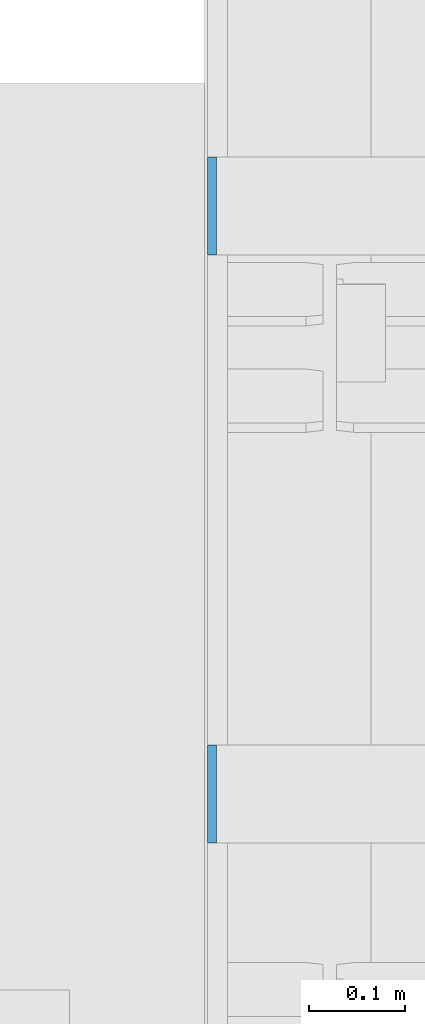
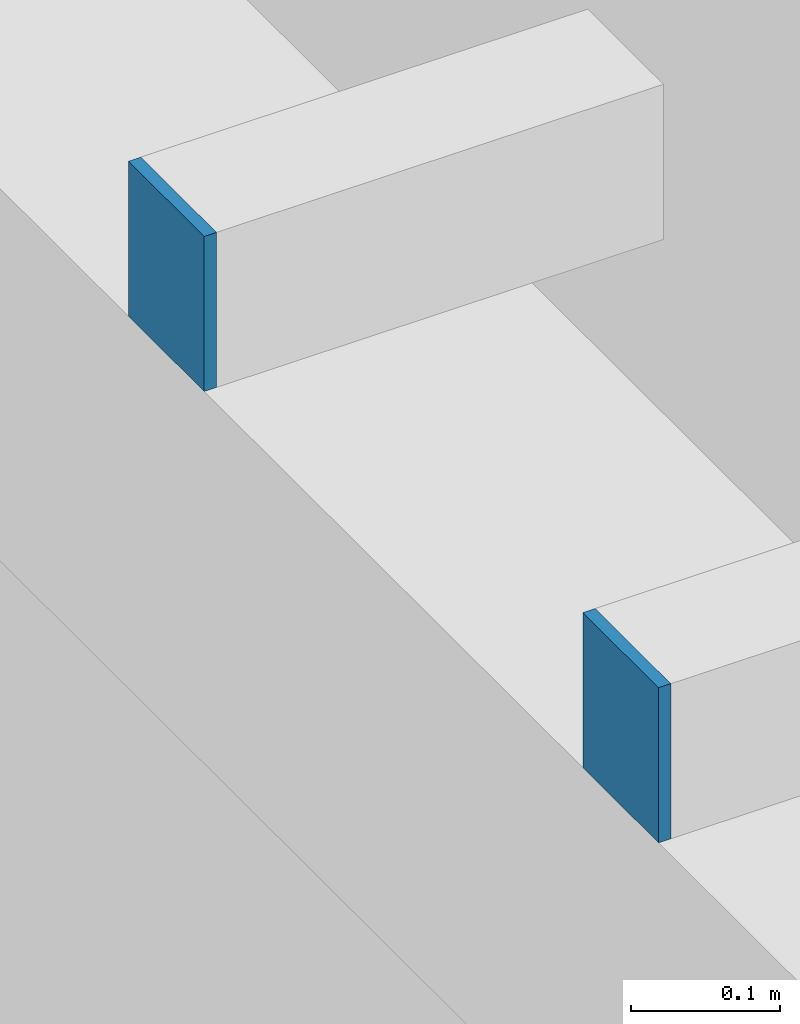
# One storey, part 446 of 1179: 2 columns, 2 elements without a shape of their own.
"""IFC2X3 building model written with IfcOpenShell, lengths in millimetres."""

from ifc_helpers import new_model, si_unit, frame, origin_with_axes, place, context, subcontext, project, spatial, faceted_brep, material, type_object, element, aggregate, save


model = new_model("IFC2X3")

# Units and contexts
model_context = context("Model", 3, precision=1e-05, world=origin_with_axes())
body_context = subcontext(model_context, "Body", "Model", "MODEL_VIEW")
ifc_project = project(units=[si_unit("LENGTHUNIT", "METRE", prefix="MILLI"), si_unit("AREAUNIT", "SQUARE_METRE"), si_unit("VOLUMEUNIT", "CUBIC_METRE"), si_unit("MASSUNIT", "GRAM", prefix="KILO"), si_unit("TIMEUNIT", "SECOND"), si_unit("PLANEANGLEUNIT", "RADIAN"), si_unit("SOLIDANGLEUNIT", "STERADIAN"), si_unit("THERMODYNAMICTEMPERATUREUNIT", "DEGREE_CELSIUS"), si_unit("LUMINOUSINTENSITYUNIT", "LUMEN")], contexts=[model_context])

# Site, building, storey
site_placement = place(None, origin_with_axes())
site = spatial("IfcSite", under=ifc_project, at=site_placement, CompositionType="ELEMENT")
building_placement = place(site_placement, origin_with_axes())
building = spatial("IfcBuilding", under=site, at=building_placement, Name="Undefined", CompositionType="ELEMENT")
storey_placement = place(building_placement, origin_with_axes())
storey = spatial("IfcBuildingStorey", under=building, at=storey_placement, Name="Undefined", CompositionType="ELEMENT", Elevation=0.0)

# Assembly, column
assembly_1_placement = place(storey_placement, origin_with_axes())
assembly_1 = element("IfcElementAssembly", 1, at=assembly_1_placement, inside=storey, Name="BEAM", AssemblyPlace="NOTDEFINED", PredefinedType="RIGID_FRAME")
ifc_material = material(Name="STEEL/A36")
column_type = type_object("IfcColumnType", PredefinedType="NOTDEFINED")
column_1_placement = place(assembly_1_placement, frame((24185.5625, 21310.6, 8013.69999998781), z_axis=(0.0, -1.0, 0.0), x_axis=(0.0, 0.0, 1.0)))
column_1 = element("IfcColumn", 2, at=column_1_placement, type_object=column_type, material=ifc_material, Name="PLATE", context=body_context, shape_type="Brep", body=[
    faceted_brep([(0.0, 4.76249999999982, -50.7999999999993), (0.0, 4.76249999999982, 50.7999999999993), (127.000000000371, 4.76249999928405, 50.8000000000002), (127.000000000371, 4.76249999928405, -50.8000000000002), (0.0, -4.76249999999982, 50.7999999999993), (127.0, -4.76250000000073, 50.7999999999993), (0.0, -4.76249999999982, -50.7999999999993), (127.0, -4.76250000000073, -50.7999999999993)], [[[0, 1, 2, 3]], [[1, 4, 5, 2]], [[4, 6, 7, 5]], [[6, 0, 3, 7]], [[5, 7, 3, 2]], [[6, 4, 1, 0]]]),
])
aggregate(assembly_1, [column_1])

assembly_2_placement = place(storey_placement, origin_with_axes())
assembly_2 = element("IfcElementAssembly", 3, at=assembly_2_placement, inside=storey, Name="BEAM", AssemblyPlace="NOTDEFINED", PredefinedType="RIGID_FRAME")
column_2_placement = place(assembly_2_placement, frame((24185.5625, 20701.0, 8013.69999998781), z_axis=(0.0, -1.0, 0.0), x_axis=(0.0, 0.0, 1.0)))
column_2 = element("IfcColumn", 4, at=column_2_placement, type_object=column_type, material=ifc_material, Name="PLATE", context=body_context, shape_type="Brep", body=[
    faceted_brep([(0.0, 4.76249999999982, -50.7999999999993), (0.0, 4.76249999999982, 50.7999999999993), (127.000000000371, 4.76249999928405, 50.8000000000002), (127.000000000371, 4.76249999928405, -50.8000000000002), (0.0, -4.76249999999982, 50.7999999999993), (127.0, -4.76250000000073, 50.7999999999993), (0.0, -4.76249999999982, -50.7999999999993), (127.0, -4.76250000000073, -50.7999999999993)], [[[0, 1, 2, 3]], [[1, 4, 5, 2]], [[4, 6, 7, 5]], [[6, 0, 3, 7]], [[5, 7, 3, 2]], [[6, 4, 1, 0]]]),
])
aggregate(assembly_2, [column_2])

save(model, "model.ifc")
